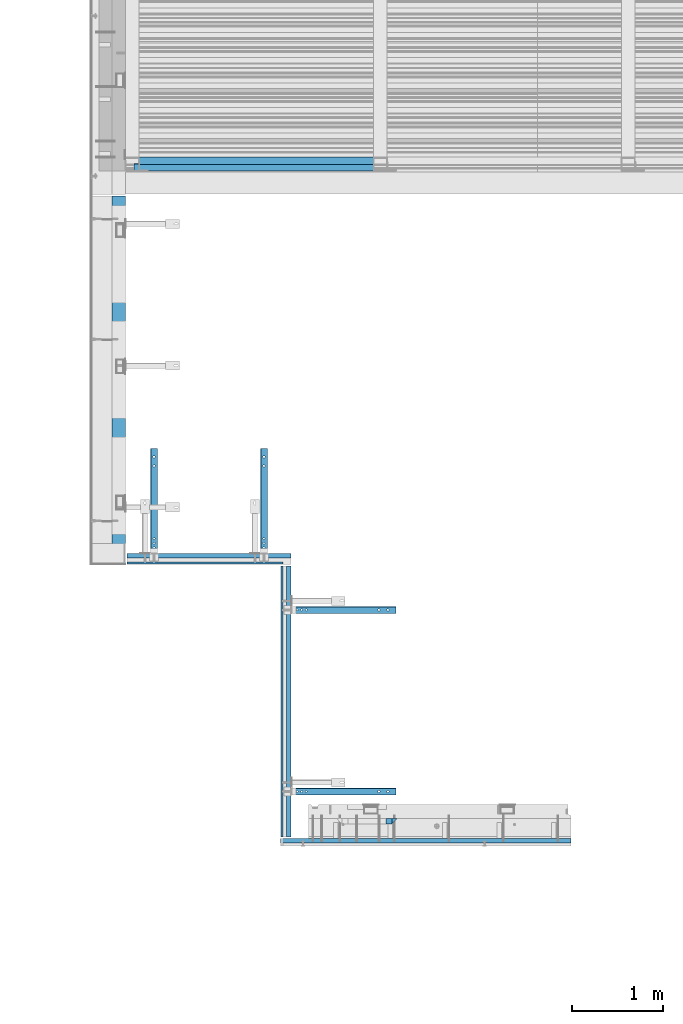
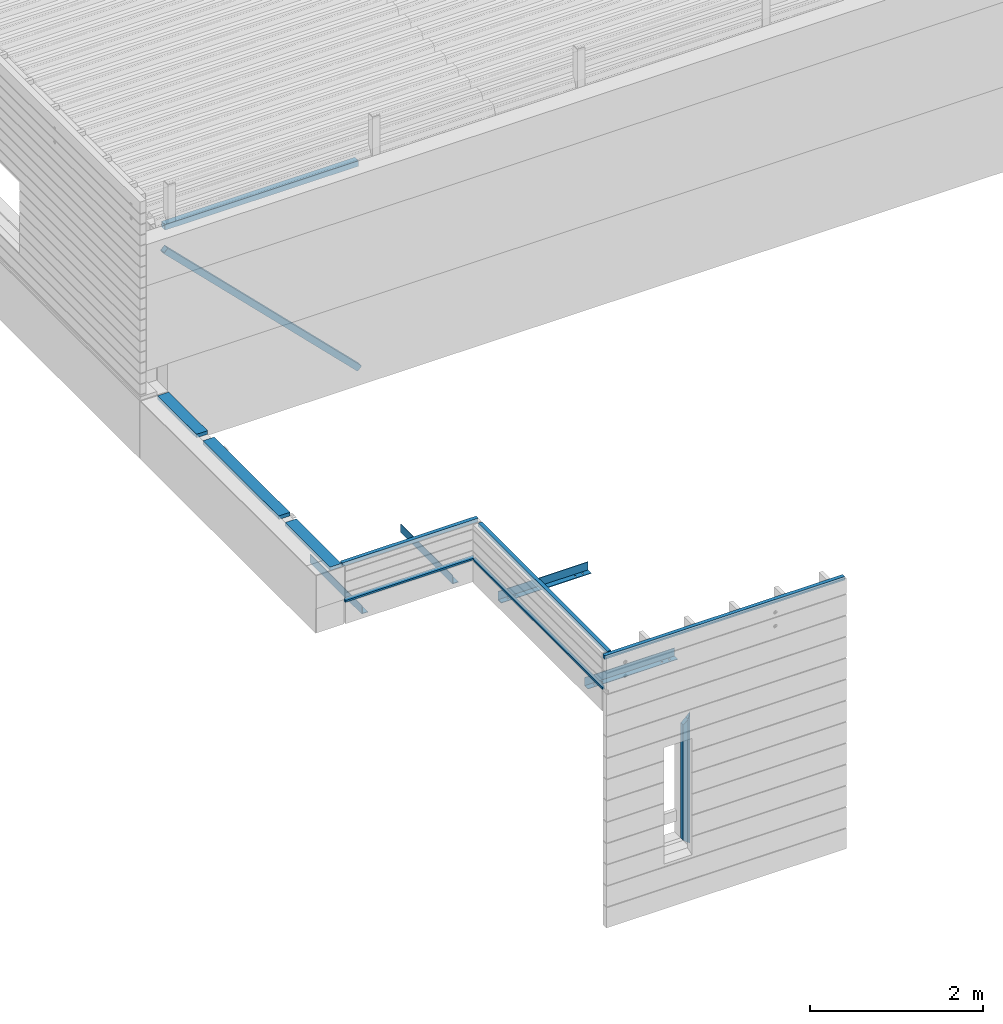
# One storey, part 17 of 153: 13 beams, 1 member, 10 elements without a shape of their own.
"""IFC2X3 building model written with IfcOpenShell, lengths in millimetres."""

from ifc_helpers import new_model, si_unit, frame, origin_with_axes, place, context, subcontext, project, spatial, faceted_brep, material, type_object, element, aggregate, save


model = new_model("IFC2X3")

# Units and contexts
model_context = context("Model", 3, precision=1e-05, world=origin_with_axes())
body_context = subcontext(model_context, "Body", "Model", "MODEL_VIEW")
ifc_project = project(units=[si_unit("LENGTHUNIT", "METRE", prefix="MILLI"), si_unit("AREAUNIT", "SQUARE_METRE"), si_unit("VOLUMEUNIT", "CUBIC_METRE"), si_unit("MASSUNIT", "GRAM", prefix="KILO"), si_unit("TIMEUNIT", "SECOND"), si_unit("PLANEANGLEUNIT", "RADIAN"), si_unit("SOLIDANGLEUNIT", "STERADIAN"), si_unit("THERMODYNAMICTEMPERATUREUNIT", "DEGREE_CELSIUS"), si_unit("LUMINOUSINTENSITYUNIT", "LUMEN")], contexts=[model_context])

# Site, building, storey
site_placement = place(None, origin_with_axes())
site = spatial("IfcSite", under=ifc_project, at=site_placement, CompositionType="ELEMENT")
building_placement = place(site_placement, origin_with_axes())
building = spatial("IfcBuilding", under=site, at=building_placement, CompositionType="ELEMENT")
storey_placement = place(building_placement, origin_with_axes())
storey = spatial("IfcBuildingStorey", under=building, at=storey_placement, Name="8", CompositionType="ELEMENT", Elevation=0.0)

# Assembly, beam
assembly_1_placement = place(storey_placement, origin_with_axes())
assembly_1 = element("IfcElementAssembly", 1, at=assembly_1_placement, inside=storey, Name="Steel Assembly", AssemblyPlace="NOTDEFINED", PredefinedType="RIGID_FRAME")
ifc_material_1 = material(Name="STEEL/S355J2")
beam_type_1 = type_object("IfcBeamType", Name="80X80X4", PredefinedType="NOTDEFINED")
beam_1_placement = place(assembly_1_placement, frame((8150.0, 15090.0, 105625.0), z_axis=(0.0, 0.0, 1.0), x_axis=(1.0, 0.0, 0.0)))
beam_1 = element("IfcBeam", 2, at=beam_1_placement, type_object=beam_type_1, material=ifc_material_1, ObjectType="80X80X4", context=body_context, shape_type="Brep", body=[
    faceted_brep([(0.0, 36.0, -36.0), (0.0, -36.0, -36.0), (2580.0, -36.0, -36.0), (2580.0, 36.0, -36.0), (0.0, -36.0, 36.0), (2580.0, -36.0, 36.0), (0.0, 36.0, 36.0), (2580.0, 36.0, 36.0), (0.0, 40.0, -40.0), (0.0, 40.0, 40.0), (2580.0, 40.0, 40.0), (2580.0, 40.0, -40.0), (0.0, -40.0, 40.0), (2580.0, -40.0, 40.0), (0.0, -40.0, -40.0), (2580.0, -40.0, -40.0)], [[[0, 1, 2, 3]], [[1, 4, 5, 2]], [[4, 6, 7, 5]], [[6, 0, 3, 7]], [[8, 9, 10, 11]], [[9, 12, 13, 10]], [[12, 14, 15, 13]], [[14, 8, 11, 15]], [[13, 15, 11, 10], [5, 7, 3, 2]], [[14, 12, 9, 8], [6, 4, 1, 0]]]),
])
aggregate(assembly_1, [beam_1])

# Assembly, member
assembly_2_placement = place(storey_placement, origin_with_axes())
assembly_2 = element("IfcElementAssembly", 3, at=assembly_2_placement, inside=storey, Name="Steel Assembly", AssemblyPlace="NOTDEFINED", PredefinedType="RIGID_FRAME")
member_type = type_object("IfcMemberType", Name="80X80X4", PredefinedType="NOTDEFINED")
member_placement = place(assembly_2_placement, frame((8121.8311532132, 15020.0, 105345.630773414), z_axis=(0.704221169665493, 0.0, 0.709980664662753), x_axis=(0.709980664662755, 0.0, -0.704221169665491)))
member = element("IfcMember", 4, at=member_placement, type_object=member_type, material=ifc_material_1, ObjectType="80X80X4", context=body_context, shape_type="Brep", body=[
    faceted_brep([(0.0, 36.0, -36.0), (0.0, -36.0, -36.0), (3640.94422381049, -36.0, -36.0), (3640.94422381049, 36.0, -36.0), (0.0, -36.0, 36.0), (3640.94422381048, -36.0, 36.0), (0.0, 36.0, 36.0), (3640.94422381048, 36.0, 36.0), (0.0, 40.0, -40.0), (0.0, 40.0, 40.0), (3640.94422381048, 40.0, 40.0), (3640.94422381048, 40.0, -40.0), (0.0, -40.0, 40.0), (3640.94422381048, -40.0, 40.0), (0.0, -40.0, -40.0), (3640.94422381048, -40.0, -40.0)], [[[0, 1, 2, 3]], [[1, 4, 5, 2]], [[4, 6, 7, 5]], [[6, 0, 3, 7]], [[8, 9, 10, 11]], [[9, 12, 13, 10]], [[12, 14, 15, 13]], [[14, 8, 11, 15]], [[13, 15, 11, 10], [5, 7, 3, 2]], [[14, 12, 9, 8], [6, 4, 1, 0]]]),
])
aggregate(assembly_2, [member])

# Assembly, beam
assembly_3_placement = place(storey_placement, origin_with_axes())
assembly_3 = element("IfcElementAssembly", 5, at=assembly_3_placement, inside=storey, AssemblyPlace="NOTDEFINED", PredefinedType="REINFORCEMENT_UNIT")
ifc_material_2 = material(Name="TIMBER")
beam_type_2 = type_object("IfcBeamType", PredefinedType="NOTDEFINED")
beam_2_placement = place(assembly_3_placement, frame((7924.99993196862, 10714.9999787075, 103545.0), z_axis=(0.0, 0.0, 1.0), x_axis=(0.0, 1.0, 0.0)))
beam_2 = element("IfcBeam", 6, at=beam_2_placement, type_object=beam_type_2, material=ifc_material_2, context=body_context, shape_type="Brep", body=[
    faceted_brep([(0.0, -75.0, -25.0), (1.81898940354586e-12, -75.0000000000009, 25.0), (1.81898940354586e-12, 75.0, 25.0), (0.0, 75.0, -25.0), (1037.99987665833, 75.0, -25.0), (1037.99987848675, -75.0000000000009, -25.0), (1037.99987848675, -75.000039166418, 25.0), (1037.99987665833, 75.0, 25.0), (3087.99987848667, -75.000585816445, 25.0), (3087.99988553667, 75.0, 25.0), (3087.99988553667, 75.0, -25.0), (3087.99987848667, -75.0000000000018, -25.0), (3987.0019971991, -75.0000000000009, 25.0), (3987.0019971991, -75.0000000000009, -25.0), (3987.0019971991, 75.0, -25.0), (3987.0019971991, 75.0, 25.0), (2937.99987848667, -75.0005787664186, 25.0), (2937.99987848667, -75.0000000000018, -25.0), (2937.99987665825, 75.0, -25.0), (2937.99987665825, 75.0, 25.0), (1187.99987848675, -75.0000462164453, 25.0), (1187.99988553675, 75.0, 25.0), (1187.99988553675, 75.0, -25.0), (1187.99987848675, -75.0000000000018, -25.0)], [[[0, 1, 2, 3]], [[0, 3, 4, 5]], [[1, 0, 5, 6]], [[2, 1, 6, 7]], [[3, 2, 7, 4]], [[6, 5, 4, 7]], [[8, 9, 10, 11]], [[12, 13, 14, 15]], [[13, 12, 8, 11]], [[14, 13, 11, 10]], [[15, 14, 10, 9]], [[12, 15, 9, 8]], [[16, 17, 18, 19]], [[20, 21, 22, 23]], [[21, 20, 16, 19]], [[22, 21, 19, 18]], [[23, 22, 18, 17]], [[20, 23, 17, 16]]]),
])
aggregate(assembly_3, [beam_2])

assembly_4_placement = place(storey_placement, origin_with_axes())
assembly_4 = element("IfcElementAssembly", 7, at=assembly_4_placement, inside=storey, AssemblyPlace="NOTDEFINED", PredefinedType="REINFORCEMENT_UNIT")
ifc_material_3 = material(Name="TIMBER/T24")
beam_type_3 = type_object("IfcBeamType", PredefinedType="NOTDEFINED")
beam_3_placement = place(assembly_4_placement, frame((9735.00005960496, 10662.5, 103080.0), z_axis=(0.0, -1.0, 0.0), x_axis=(-1.0, 3.00000001838171e-08, 0.0)))
beam_3 = element("IfcBeam", 8, at=beam_3_placement, type_object=beam_type_3, material=ifc_material_3, context=body_context, shape_type="Brep", body=[
    faceted_brep([(0.0, -25.0, -12.5), (1720.00000000001, -25.0, -12.5), (1720.00000000001, -1.16415321826935e-10, 12.5), (1.45519152283669e-11, -3.63797880709171e-12, 12.4999999999964), (0.0, 25.0, -12.5), (0.0, 25.0, 12.5), (1720.00000000001, 25.0, 12.5), (1720.00000000001, 25.0, -12.5)], [[[0, 1, 2, 3]], [[4, 5, 6, 7]], [[5, 4, 0, 3]], [[6, 5, 3, 2]], [[7, 6, 2, 1]], [[4, 7, 1, 0]]]),
])

assembly_5_placement = place(storey_placement, origin_with_axes())
assembly_5 = element("IfcElementAssembly", 9, at=assembly_5_placement, inside=storey, AssemblyPlace="NOTDEFINED", PredefinedType="REINFORCEMENT_UNIT")
beam_4_placement = place(assembly_5_placement, frame((9722.5, 7645.0, 103080.0), z_axis=(-1.0, 3.00000001838171e-08, 0.0), x_axis=(0.0, 1.0, 0.0)))
beam_4 = element("IfcBeam", 10, at=beam_4_placement, type_object=beam_type_3, material=ifc_material_3, context=body_context, shape_type="Brep", body=[
    faceted_brep([(2985.0, -25.0000000000291, -12.5000000000036), (2985.0, -2.91038304567337e-11, 12.5), (1.45519152283669e-11, -3.63797880709171e-12, 12.4999999999964), (0.0, -25.0, -12.5), (0.0, 25.0, -12.5), (0.0, 25.0, 12.5), (2985.0, 25.0, 12.5), (2985.0, 25.0, -12.5)], [[[0, 1, 2, 3]], [[4, 5, 6, 7]], [[4, 7, 0, 3]], [[5, 4, 3, 2]], [[6, 5, 2, 1]], [[7, 6, 1, 0]]]),
])

assembly_6_placement = place(storey_placement, origin_with_axes())
assembly_6 = element("IfcElementAssembly", 11, at=assembly_6_placement, inside=storey, Name="Steel Assembly", AssemblyPlace="NOTDEFINED", PredefinedType="RIGID_FRAME")
ifc_material_4 = material(Name="STEEL/S235J2")
beam_type_4 = type_object("IfcBeamType", PredefinedType="NOTDEFINED")
beam_5_placement = place(assembly_6_placement, frame((8315.00005960493, 10720.0, 102815.0), z_axis=(0.0, 0.0, 1.0), x_axis=(0.0, 1.0, 0.0)))
beam_5 = element("IfcBeam", 12, at=beam_5_placement, type_object=beam_type_4, material=ifc_material_4, context=body_context, shape_type="Brep", body=[
    faceted_brep([(152.928932188135, -7.07106781186485, -52.0), (152.928932188135, -7.07106781186485, -60.0), (150.0, 0.0, -60.0), (150.0, 0.0, -52.0), (152.928932188135, 7.07106781186485, -60.0), (152.928932188135, 7.07106781186485, -52.0), (160.0, 10.0, -60.0), (160.0, 10.0, -52.0), (167.071067811865, 7.07106781186485, -60.0), (167.071067811865, 7.07106781186485, -52.0), (170.0, 0.0, -60.0), (170.0, 0.0, -52.0), (167.071067811865, -7.07106781186485, -60.0), (167.071067811865, -7.07106781186485, -52.0), (160.0, -10.0, -60.0), (160.0, -10.0, -52.0), (0.0, -40.0, -52.0), (0.0, -40.0, -60.0), (1200.0, -40.0, -60.0), (1200.0, -40.0, -52.0), (0.0, 32.0, -52.0), (0.0, 32.0, 60.0), (0.0, 40.0, 60.0), (0.0, 40.0, -60.0), (1200.0, 32.0, -52.0), (1200.0, 32.0, 60.0), (1200.0, 40.0, 60.0), (1200.0, 40.0, -60.0), (1115.75, -9.95929214352145, -52.0), (1115.75, -9.95929214352145, -60.0), (1110.0, -11.5, -60.0), (1110.0, -11.5, -52.0), (1119.95929214352, -5.75, -52.0), (1119.95929214352, -5.75, -60.0), (1121.5, 0.0, -52.0), (1121.5, 0.0, -60.0), (1119.95929214352, 5.75, -52.0), (1119.95929214352, 5.75, -60.0), (1115.75, 9.95929214352145, -52.0), (1115.75, 9.95929214352145, -60.0), (1110.0, 11.5, -52.0), (1110.0, 11.5, -60.0), (1104.25, 9.95929214352145, -52.0), (1104.25, 9.95929214352145, -60.0), (1100.04070785648, 5.75, -52.0), (1100.04070785648, 5.75, -60.0), (1098.5, 0.0, -52.0), (1098.5, 0.0, -60.0), (1100.04070785648, -5.75, -52.0), (1100.04070785648, -5.75, -60.0), (1104.25, -9.95929214352145, -52.0), (1104.25, -9.95929214352145, -60.0), (1015.75, -9.95929214352145, -52.0), (1015.75, -9.95929214352145, -60.0), (1010.0, -11.5, -60.0), (1010.0, -11.5, -52.0), (1019.95929214352, -5.75, -52.0), (1019.95929214352, -5.75, -60.0), (1021.5, 0.0, -52.0), (1021.5, 0.0, -60.0), (1019.95929214352, 5.75, -52.0), (1019.95929214352, 5.75, -60.0), (1015.75, 9.95929214352145, -52.0), (1015.75, 9.95929214352145, -60.0), (1010.0, 11.5, -52.0), (1010.0, 11.5, -60.0), (1004.25, 9.95929214352145, -52.0), (1004.25, 9.95929214352145, -60.0), (1000.04070785648, 5.75, -52.0), (1000.04070785648, 5.75, -60.0), (998.5, 0.0, -52.0), (998.5, 0.0, -60.0), (1000.04070785648, -5.75, -52.0), (1000.04070785648, -5.75, -60.0), (1004.25, -9.95929214352145, -52.0), (1004.25, -9.95929214352145, -60.0), (117.071067811865, -7.07106781186485, -52.0), (117.071067811865, -7.07106781186485, -60.0), (110.0, -10.0, -60.0), (110.0, -10.0, -52.0), (120.0, 0.0, -52.0), (120.0, 0.0, -60.0), (117.071067811865, 7.07106781186485, -52.0), (117.071067811865, 7.07106781186485, -60.0), (110.0, 10.0, -52.0), (110.0, 10.0, -60.0), (102.928932188135, 7.07106781186485, -52.0), (102.928932188135, 7.07106781186485, -60.0), (100.0, 0.0, -52.0), (100.0, 0.0, -60.0), (102.928932188135, -7.07106781186485, -52.0), (102.928932188135, -7.07106781186485, -60.0), (200.0, 0.0, -52.0), (202.928932188135, 7.07106781186485, -52.0), (210.0, 10.0, -52.0), (217.071067811865, 7.07106781186485, -52.0), (220.0, 0.0, -52.0), (217.071067811865, -7.07106781186485, -52.0), (210.0, -10.0, -52.0), (202.928932188135, -7.07106781186485, -52.0), (220.0, 0.0, -60.0), (217.071067811865, -7.07106781186485, -60.0), (217.071067811865, 7.07106781186485, -60.0), (210.0, 10.0, -60.0), (202.928932188135, 7.07106781186485, -60.0), (200.0, 0.0, -60.0), (202.928932188135, -7.07106781186485, -60.0), (210.0, -10.0, -60.0)], [[[0, 1, 2, 3]], [[3, 2, 4, 5]], [[5, 4, 6, 7]], [[7, 6, 8, 9]], [[9, 8, 10, 11]], [[11, 10, 12, 13]], [[13, 12, 14, 15]], [[15, 14, 1, 0]], [[16, 17, 18, 19]], [[17, 16, 20, 21, 22, 23]], [[21, 20, 24, 25]], [[22, 21, 25, 26]], [[23, 22, 26, 27]], [[25, 24, 19, 18, 27, 26]], [[28, 29, 30, 31]], [[32, 33, 29, 28]], [[34, 35, 33, 32]], [[36, 37, 35, 34]], [[38, 39, 37, 36]], [[40, 41, 39, 38]], [[42, 43, 41, 40]], [[44, 45, 43, 42]], [[46, 47, 45, 44]], [[48, 49, 47, 46]], [[50, 51, 49, 48]], [[31, 30, 51, 50]], [[52, 53, 54, 55]], [[56, 57, 53, 52]], [[58, 59, 57, 56]], [[60, 61, 59, 58]], [[62, 63, 61, 60]], [[64, 65, 63, 62]], [[66, 67, 65, 64]], [[68, 69, 67, 66]], [[70, 71, 69, 68]], [[72, 73, 71, 70]], [[74, 75, 73, 72]], [[55, 54, 75, 74]], [[76, 77, 78, 79]], [[80, 81, 77, 76]], [[82, 83, 81, 80]], [[84, 85, 83, 82]], [[86, 87, 85, 84]], [[88, 89, 87, 86]], [[90, 91, 89, 88]], [[79, 78, 91, 90]], [[20, 16, 19, 24], [3, 5, 7, 9, 11, 13, 15, 0], [92, 93, 94, 95, 96, 97, 98, 99], [88, 86, 84, 82, 80, 76, 79, 90], [72, 70, 68, 66, 64, 62, 60, 58, 56, 52, 55, 74], [48, 46, 44, 42, 40, 38, 36, 34, 32, 28, 31, 50]], [[96, 100, 101, 97]], [[95, 102, 100, 96]], [[94, 103, 102, 95]], [[93, 104, 103, 94]], [[92, 105, 104, 93]], [[99, 106, 105, 92]], [[98, 107, 106, 99]], [[97, 101, 107, 98]], [[17, 23, 27, 18], [10, 8, 6, 4, 2, 1, 14, 12], [100, 102, 103, 104, 105, 106, 107, 101], [81, 83, 85, 87, 89, 91, 78, 77], [57, 59, 61, 63, 65, 67, 69, 71, 73, 75, 54, 53], [33, 35, 37, 39, 41, 43, 45, 47, 49, 51, 30, 29]]]),
])
aggregate(assembly_6, [beam_5])

assembly_7_placement = place(storey_placement, origin_with_axes())
assembly_7 = element("IfcElementAssembly", 13, at=assembly_7_placement, inside=storey, Name="Steel Assembly", AssemblyPlace="NOTDEFINED", PredefinedType="RIGID_FRAME")
beam_6_placement = place(assembly_7_placement, frame((9779.99999999999, 10145.0, 102815.0), z_axis=(0.0, 0.0, 1.0), x_axis=(1.0, 0.0, 0.0)))
beam_6 = element("IfcBeam", 14, at=beam_6_placement, type_object=beam_type_4, material=ifc_material_4, context=body_context, shape_type="Brep", body=[
    faceted_brep([(167.071067811865, -7.07106781186485, -52.0), (167.071067811865, -7.07106781186485, -60.0), (160.0, -10.0, -60.0), (160.0, -10.0, -52.0), (152.928932188135, -7.07106781186485, -60.0), (152.928932188135, -7.07106781186485, -52.0), (150.0, 0.0, -60.0), (150.0, 0.0, -52.0), (152.928932188135, 7.07106781186485, -60.0), (152.928932188135, 7.07106781186485, -52.0), (160.0, 10.0, -60.0), (160.0, 10.0, -52.0), (167.071067811865, 7.07106781186485, -60.0), (167.071067811865, 7.07106781186485, -52.0), (170.0, 0.0, -60.0), (170.0, 0.0, -52.0), (0.0, -40.0, -52.0), (0.0, -40.0, -60.0), (1200.0, -40.0, -60.0), (1200.0, -40.0, -52.0), (0.0, 32.0, -52.0), (0.0, 32.0, 60.0), (0.0, 40.0, 60.0), (0.0, 40.0, -60.0), (1200.0, 32.0, -52.0), (1200.0, 32.0, 60.0), (1200.0, 40.0, 60.0), (1200.0, 40.0, -60.0), (1119.95929214352, 5.75, -52.0), (1119.95929214352, 5.75, -60.0), (1121.5, 0.0, -60.0), (1121.5, 0.0, -52.0), (1115.75, 9.95929214352145, -52.0), (1115.75, 9.95929214352145, -60.0), (1110.0, 11.5, -52.0), (1110.0, 11.5, -60.0), (1104.25, 9.95929214352145, -52.0), (1104.25, 9.95929214352145, -60.0), (1100.04070785648, 5.75, -52.0), (1100.04070785648, 5.75, -60.0), (1098.5, 0.0, -52.0), (1098.5, 0.0, -60.0), (1100.04070785648, -5.75, -52.0), (1100.04070785648, -5.75, -60.0), (1104.25, -9.95929214352145, -52.0), (1104.25, -9.95929214352145, -60.0), (1110.0, -11.5, -52.0), (1110.0, -11.5, -60.0), (1115.75, -9.95929214352145, -52.0), (1115.75, -9.95929214352145, -60.0), (1119.95929214352, -5.75, -52.0), (1119.95929214352, -5.75, -60.0), (1019.95929214352, 5.75, -52.0), (1019.95929214352, 5.75, -60.0), (1021.5, 0.0, -60.0), (1021.5, 0.0, -52.0), (1015.75, 9.95929214352145, -52.0), (1015.75, 9.95929214352145, -60.0), (1010.0, 11.5, -52.0), (1010.0, 11.5, -60.0), (1004.25, 9.95929214352145, -52.0), (1004.25, 9.95929214352145, -60.0), (1000.04070785648, 5.75, -52.0), (1000.04070785648, 5.75, -60.0), (998.5, 0.0, -52.0), (998.5, 0.0, -60.0), (1000.04070785648, -5.75, -52.0), (1000.04070785648, -5.75, -60.0), (1004.25, -9.95929214352145, -52.0), (1004.25, -9.95929214352145, -60.0), (1010.0, -11.5, -52.0), (1010.0, -11.5, -60.0), (1015.75, -9.95929214352145, -52.0), (1015.75, -9.95929214352145, -60.0), (1019.95929214352, -5.75, -52.0), (1019.95929214352, -5.75, -60.0), (117.071067811865, 7.07106781186485, -52.0), (117.071067811865, 7.07106781186485, -60.0), (120.0, 0.0, -60.0), (120.0, 0.0, -52.0), (110.0, 10.0, -52.0), (110.0, 10.0, -60.0), (102.928932188135, 7.07106781186485, -52.0), (102.928932188135, 7.07106781186485, -60.0), (100.0, 0.0, -52.0), (100.0, 0.0, -60.0), (102.928932188135, -7.07106781186485, -52.0), (102.928932188135, -7.07106781186485, -60.0), (110.0, -10.0, -52.0), (110.0, -10.0, -60.0), (117.071067811865, -7.07106781186485, -52.0), (117.071067811865, -7.07106781186485, -60.0), (200.0, 0.0, -52.0), (202.928932188135, 7.07106781186485, -52.0), (210.0, 10.0, -52.0), (217.071067811865, 7.07106781186485, -52.0), (220.0, 0.0, -52.0), (217.071067811865, -7.07106781186485, -52.0), (210.0, -10.0, -52.0), (202.928932188135, -7.07106781186485, -52.0), (210.0, 10.0, -60.0), (217.071067811865, 7.07106781186485, -60.0), (202.928932188135, 7.07106781186485, -60.0), (200.0, 0.0, -60.0), (202.928932188135, -7.07106781186485, -60.0), (210.0, -10.0, -60.0), (217.071067811865, -7.07106781186485, -60.0), (220.0, 0.0, -60.0)], [[[0, 1, 2, 3]], [[3, 2, 4, 5]], [[5, 4, 6, 7]], [[7, 6, 8, 9]], [[9, 8, 10, 11]], [[11, 10, 12, 13]], [[13, 12, 14, 15]], [[15, 14, 1, 0]], [[16, 17, 18, 19]], [[17, 16, 20, 21, 22, 23]], [[21, 20, 24, 25]], [[22, 21, 25, 26]], [[23, 22, 26, 27]], [[25, 24, 19, 18, 27, 26]], [[28, 29, 30, 31]], [[32, 33, 29, 28]], [[34, 35, 33, 32]], [[36, 37, 35, 34]], [[38, 39, 37, 36]], [[40, 41, 39, 38]], [[42, 43, 41, 40]], [[44, 45, 43, 42]], [[46, 47, 45, 44]], [[48, 49, 47, 46]], [[50, 51, 49, 48]], [[31, 30, 51, 50]], [[52, 53, 54, 55]], [[56, 57, 53, 52]], [[58, 59, 57, 56]], [[60, 61, 59, 58]], [[62, 63, 61, 60]], [[64, 65, 63, 62]], [[66, 67, 65, 64]], [[68, 69, 67, 66]], [[70, 71, 69, 68]], [[72, 73, 71, 70]], [[74, 75, 73, 72]], [[55, 54, 75, 74]], [[76, 77, 78, 79]], [[80, 81, 77, 76]], [[82, 83, 81, 80]], [[84, 85, 83, 82]], [[86, 87, 85, 84]], [[88, 89, 87, 86]], [[90, 91, 89, 88]], [[79, 78, 91, 90]], [[20, 16, 19, 24], [7, 9, 11, 13, 15, 0, 3, 5], [92, 93, 94, 95, 96, 97, 98, 99], [84, 82, 80, 76, 79, 90, 88, 86], [66, 64, 62, 60, 58, 56, 52, 55, 74, 72, 70, 68], [42, 40, 38, 36, 34, 32, 28, 31, 50, 48, 46, 44]], [[94, 100, 101, 95]], [[93, 102, 100, 94]], [[92, 103, 102, 93]], [[99, 104, 103, 92]], [[98, 105, 104, 99]], [[97, 106, 105, 98]], [[96, 107, 106, 97]], [[95, 101, 107, 96]], [[17, 23, 27, 18], [14, 12, 10, 8, 6, 4, 2, 1], [107, 101, 100, 102, 103, 104, 105, 106], [78, 77, 81, 83, 85, 87, 89, 91], [75, 54, 53, 57, 59, 61, 63, 65, 67, 69, 71, 73], [51, 30, 29, 33, 35, 37, 39, 41, 43, 45, 47, 49]]]),
])
aggregate(assembly_7, [beam_6])

assembly_8_placement = place(storey_placement, origin_with_axes())
assembly_8 = element("IfcElementAssembly", 15, at=assembly_8_placement, inside=storey, Name="Steel Assembly", AssemblyPlace="NOTDEFINED", PredefinedType="RIGID_FRAME")
beam_7_placement = place(assembly_8_placement, frame((9525.0, 10720.0, 102815.0), z_axis=(0.0, 0.0, 1.0), x_axis=(0.0, 1.0, 0.0)))
beam_7 = element("IfcBeam", 16, at=beam_7_placement, type_object=beam_type_4, material=ifc_material_4, context=body_context, shape_type="Brep", body=[
    faceted_brep([(152.928932188135, -7.07106781186485, -52.0), (152.928932188135, -7.07106781186485, -60.0), (150.0, 0.0, -60.0), (150.0, 0.0, -52.0), (152.928932188135, 7.07106781186485, -60.0), (152.928932188135, 7.07106781186485, -52.0), (160.0, 10.0, -60.0), (160.0, 10.0, -52.0), (167.071067811865, 7.07106781186485, -60.0), (167.071067811865, 7.07106781186485, -52.0), (170.0, 0.0, -60.0), (170.0, 0.0, -52.0), (167.071067811865, -7.07106781186485, -60.0), (167.071067811865, -7.07106781186485, -52.0), (160.0, -10.0, -60.0), (160.0, -10.0, -52.0), (0.0, -40.0, -52.0), (0.0, -40.0, -60.0), (1200.0, -40.0, -60.0), (1200.0, -40.0, -52.0), (0.0, 32.0, -52.0), (0.0, 32.0, 60.0), (0.0, 40.0, 60.0), (0.0, 40.0, -60.0), (1200.0, 32.0, -52.0), (1200.0, 32.0, 60.0), (1200.0, 40.0, 60.0), (1200.0, 40.0, -60.0), (1115.75, -9.95929214352145, -52.0), (1115.75, -9.95929214352145, -60.0), (1110.0, -11.5, -60.0), (1110.0, -11.5, -52.0), (1119.95929214352, -5.75, -52.0), (1119.95929214352, -5.75, -60.0), (1121.5, 0.0, -52.0), (1121.5, 0.0, -60.0), (1119.95929214352, 5.75, -52.0), (1119.95929214352, 5.75, -60.0), (1115.75, 9.95929214352145, -52.0), (1115.75, 9.95929214352145, -60.0), (1110.0, 11.5, -52.0), (1110.0, 11.5, -60.0), (1104.25, 9.95929214352145, -52.0), (1104.25, 9.95929214352145, -60.0), (1100.04070785648, 5.75, -52.0), (1100.04070785648, 5.75, -60.0), (1098.5, 0.0, -52.0), (1098.5, 0.0, -60.0), (1100.04070785648, -5.75, -52.0), (1100.04070785648, -5.75, -60.0), (1104.25, -9.95929214352145, -52.0), (1104.25, -9.95929214352145, -60.0), (1015.75, -9.95929214352145, -52.0), (1015.75, -9.95929214352145, -60.0), (1010.0, -11.5, -60.0), (1010.0, -11.5, -52.0), (1019.95929214352, -5.75, -52.0), (1019.95929214352, -5.75, -60.0), (1021.5, 0.0, -52.0), (1021.5, 0.0, -60.0), (1019.95929214352, 5.75, -52.0), (1019.95929214352, 5.75, -60.0), (1015.75, 9.95929214352145, -52.0), (1015.75, 9.95929214352145, -60.0), (1010.0, 11.5, -52.0), (1010.0, 11.5, -60.0), (1004.25, 9.95929214352145, -52.0), (1004.25, 9.95929214352145, -60.0), (1000.04070785648, 5.75, -52.0), (1000.04070785648, 5.75, -60.0), (998.5, 0.0, -52.0), (998.5, 0.0, -60.0), (1000.04070785648, -5.75, -52.0), (1000.04070785648, -5.75, -60.0), (1004.25, -9.95929214352145, -52.0), (1004.25, -9.95929214352145, -60.0), (117.071067811865, -7.07106781186485, -52.0), (117.071067811865, -7.07106781186485, -60.0), (110.0, -10.0, -60.0), (110.0, -10.0, -52.0), (120.0, 0.0, -52.0), (120.0, 0.0, -60.0), (117.071067811865, 7.07106781186485, -52.0), (117.071067811865, 7.07106781186485, -60.0), (110.0, 10.0, -52.0), (110.0, 10.0, -60.0), (102.928932188135, 7.07106781186485, -52.0), (102.928932188135, 7.07106781186485, -60.0), (100.0, 0.0, -52.0), (100.0, 0.0, -60.0), (102.928932188135, -7.07106781186485, -52.0), (102.928932188135, -7.07106781186485, -60.0), (200.0, 0.0, -52.0), (202.928932188135, 7.07106781186485, -52.0), (210.0, 10.0, -52.0), (217.071067811865, 7.07106781186485, -52.0), (220.0, 0.0, -52.0), (217.071067811865, -7.07106781186485, -52.0), (210.0, -10.0, -52.0), (202.928932188135, -7.07106781186485, -52.0), (220.0, 0.0, -60.0), (217.071067811865, -7.07106781186485, -60.0), (217.071067811865, 7.07106781186485, -60.0), (210.0, 10.0, -60.0), (202.928932188135, 7.07106781186485, -60.0), (200.0, 0.0, -60.0), (202.928932188135, -7.07106781186485, -60.0), (210.0, -10.0, -60.0)], [[[0, 1, 2, 3]], [[3, 2, 4, 5]], [[5, 4, 6, 7]], [[7, 6, 8, 9]], [[9, 8, 10, 11]], [[11, 10, 12, 13]], [[13, 12, 14, 15]], [[15, 14, 1, 0]], [[16, 17, 18, 19]], [[17, 16, 20, 21, 22, 23]], [[21, 20, 24, 25]], [[22, 21, 25, 26]], [[23, 22, 26, 27]], [[25, 24, 19, 18, 27, 26]], [[28, 29, 30, 31]], [[32, 33, 29, 28]], [[34, 35, 33, 32]], [[36, 37, 35, 34]], [[38, 39, 37, 36]], [[40, 41, 39, 38]], [[42, 43, 41, 40]], [[44, 45, 43, 42]], [[46, 47, 45, 44]], [[48, 49, 47, 46]], [[50, 51, 49, 48]], [[31, 30, 51, 50]], [[52, 53, 54, 55]], [[56, 57, 53, 52]], [[58, 59, 57, 56]], [[60, 61, 59, 58]], [[62, 63, 61, 60]], [[64, 65, 63, 62]], [[66, 67, 65, 64]], [[68, 69, 67, 66]], [[70, 71, 69, 68]], [[72, 73, 71, 70]], [[74, 75, 73, 72]], [[55, 54, 75, 74]], [[76, 77, 78, 79]], [[80, 81, 77, 76]], [[82, 83, 81, 80]], [[84, 85, 83, 82]], [[86, 87, 85, 84]], [[88, 89, 87, 86]], [[90, 91, 89, 88]], [[79, 78, 91, 90]], [[20, 16, 19, 24], [3, 5, 7, 9, 11, 13, 15, 0], [92, 93, 94, 95, 96, 97, 98, 99], [88, 86, 84, 82, 80, 76, 79, 90], [72, 70, 68, 66, 64, 62, 60, 58, 56, 52, 55, 74], [48, 46, 44, 42, 40, 38, 36, 34, 32, 28, 31, 50]], [[96, 100, 101, 97]], [[95, 102, 100, 96]], [[94, 103, 102, 95]], [[93, 104, 103, 94]], [[92, 105, 104, 93]], [[99, 106, 105, 92]], [[98, 107, 106, 99]], [[97, 101, 107, 98]], [[17, 23, 27, 18], [10, 8, 6, 4, 2, 1, 14, 12], [100, 102, 103, 104, 105, 106, 107, 101], [81, 83, 85, 87, 89, 91, 78, 77], [57, 59, 61, 63, 65, 67, 69, 71, 73, 75, 54, 53], [33, 35, 37, 39, 41, 43, 45, 47, 49, 51, 30, 29]]]),
])
aggregate(assembly_8, [beam_7])

assembly_9_placement = place(storey_placement, origin_with_axes())
assembly_9 = element("IfcElementAssembly", 17, at=assembly_9_placement, inside=storey, Name="Steel Assembly", AssemblyPlace="NOTDEFINED", PredefinedType="RIGID_FRAME")
beam_8_placement = place(assembly_9_placement, frame((9779.99999999999, 8145.0, 102815.0), z_axis=(0.0, 0.0, 1.0), x_axis=(1.0, 0.0, 0.0)))
beam_8 = element("IfcBeam", 18, at=beam_8_placement, type_object=beam_type_4, material=ifc_material_4, context=body_context, shape_type="Brep", body=[
    faceted_brep([(167.071067811865, -7.07106781186485, -52.0), (167.071067811865, -7.07106781186485, -60.0), (160.0, -10.0, -60.0), (160.0, -10.0, -52.0), (152.928932188135, -7.07106781186485, -60.0), (152.928932188135, -7.07106781186485, -52.0), (150.0, 0.0, -60.0), (150.0, 0.0, -52.0), (152.928932188135, 7.07106781186485, -60.0), (152.928932188135, 7.07106781186485, -52.0), (160.0, 10.0, -60.0), (160.0, 10.0, -52.0), (167.071067811865, 7.07106781186485, -60.0), (167.071067811865, 7.07106781186485, -52.0), (170.0, 0.0, -60.0), (170.0, 0.0, -52.0), (0.0, -40.0, -52.0), (0.0, -40.0, -60.0), (1200.0, -40.0, -60.0), (1200.0, -40.0, -52.0), (0.0, 32.0, -52.0), (0.0, 32.0, 60.0), (0.0, 40.0, 60.0), (0.0, 40.0, -60.0), (1200.0, 32.0, -52.0), (1200.0, 32.0, 60.0), (1200.0, 40.0, 60.0), (1200.0, 40.0, -60.0), (1119.95929214352, 5.75, -52.0), (1119.95929214352, 5.75, -60.0), (1121.5, 0.0, -60.0), (1121.5, 0.0, -52.0), (1115.75, 9.95929214352145, -52.0), (1115.75, 9.95929214352145, -60.0), (1110.0, 11.5, -52.0), (1110.0, 11.5, -60.0), (1104.25, 9.95929214352145, -52.0), (1104.25, 9.95929214352145, -60.0), (1100.04070785648, 5.75, -52.0), (1100.04070785648, 5.75, -60.0), (1098.5, 0.0, -52.0), (1098.5, 0.0, -60.0), (1100.04070785648, -5.75, -52.0), (1100.04070785648, -5.75, -60.0), (1104.25, -9.95929214352145, -52.0), (1104.25, -9.95929214352145, -60.0), (1110.0, -11.5, -52.0), (1110.0, -11.5, -60.0), (1115.75, -9.95929214352145, -52.0), (1115.75, -9.95929214352145, -60.0), (1119.95929214352, -5.75, -52.0), (1119.95929214352, -5.75, -60.0), (1019.95929214352, 5.75, -52.0), (1019.95929214352, 5.75, -60.0), (1021.5, 0.0, -60.0), (1021.5, 0.0, -52.0), (1015.75, 9.95929214352145, -52.0), (1015.75, 9.95929214352145, -60.0), (1010.0, 11.5, -52.0), (1010.0, 11.5, -60.0), (1004.25, 9.95929214352145, -52.0), (1004.25, 9.95929214352145, -60.0), (1000.04070785648, 5.75, -52.0), (1000.04070785648, 5.75, -60.0), (998.5, 0.0, -52.0), (998.5, 0.0, -60.0), (1000.04070785648, -5.75, -52.0), (1000.04070785648, -5.75, -60.0), (1004.25, -9.95929214352145, -52.0), (1004.25, -9.95929214352145, -60.0), (1010.0, -11.5, -52.0), (1010.0, -11.5, -60.0), (1015.75, -9.95929214352145, -52.0), (1015.75, -9.95929214352145, -60.0), (1019.95929214352, -5.75, -52.0), (1019.95929214352, -5.75, -60.0), (117.071067811865, 7.07106781186485, -52.0), (117.071067811865, 7.07106781186485, -60.0), (120.0, 0.0, -60.0), (120.0, 0.0, -52.0), (110.0, 10.0, -52.0), (110.0, 10.0, -60.0), (102.928932188135, 7.07106781186485, -52.0), (102.928932188135, 7.07106781186485, -60.0), (100.0, 0.0, -52.0), (100.0, 0.0, -60.0), (102.928932188135, -7.07106781186485, -52.0), (102.928932188135, -7.07106781186485, -60.0), (110.0, -10.0, -52.0), (110.0, -10.0, -60.0), (117.071067811865, -7.07106781186485, -52.0), (117.071067811865, -7.07106781186485, -60.0), (200.0, 0.0, -52.0), (202.928932188135, 7.07106781186485, -52.0), (210.0, 10.0, -52.0), (217.071067811865, 7.07106781186485, -52.0), (220.0, 0.0, -52.0), (217.071067811865, -7.07106781186485, -52.0), (210.0, -10.0, -52.0), (202.928932188135, -7.07106781186485, -52.0), (210.0, 10.0, -60.0), (217.071067811865, 7.07106781186485, -60.0), (202.928932188135, 7.07106781186485, -60.0), (200.0, 0.0, -60.0), (202.928932188135, -7.07106781186485, -60.0), (210.0, -10.0, -60.0), (217.071067811865, -7.07106781186485, -60.0), (220.0, 0.0, -60.0)], [[[0, 1, 2, 3]], [[3, 2, 4, 5]], [[5, 4, 6, 7]], [[7, 6, 8, 9]], [[9, 8, 10, 11]], [[11, 10, 12, 13]], [[13, 12, 14, 15]], [[15, 14, 1, 0]], [[16, 17, 18, 19]], [[17, 16, 20, 21, 22, 23]], [[21, 20, 24, 25]], [[22, 21, 25, 26]], [[23, 22, 26, 27]], [[25, 24, 19, 18, 27, 26]], [[28, 29, 30, 31]], [[32, 33, 29, 28]], [[34, 35, 33, 32]], [[36, 37, 35, 34]], [[38, 39, 37, 36]], [[40, 41, 39, 38]], [[42, 43, 41, 40]], [[44, 45, 43, 42]], [[46, 47, 45, 44]], [[48, 49, 47, 46]], [[50, 51, 49, 48]], [[31, 30, 51, 50]], [[52, 53, 54, 55]], [[56, 57, 53, 52]], [[58, 59, 57, 56]], [[60, 61, 59, 58]], [[62, 63, 61, 60]], [[64, 65, 63, 62]], [[66, 67, 65, 64]], [[68, 69, 67, 66]], [[70, 71, 69, 68]], [[72, 73, 71, 70]], [[74, 75, 73, 72]], [[55, 54, 75, 74]], [[76, 77, 78, 79]], [[80, 81, 77, 76]], [[82, 83, 81, 80]], [[84, 85, 83, 82]], [[86, 87, 85, 84]], [[88, 89, 87, 86]], [[90, 91, 89, 88]], [[79, 78, 91, 90]], [[20, 16, 19, 24], [7, 9, 11, 13, 15, 0, 3, 5], [92, 93, 94, 95, 96, 97, 98, 99], [84, 82, 80, 76, 79, 90, 88, 86], [66, 64, 62, 60, 58, 56, 52, 55, 74, 72, 70, 68], [42, 40, 38, 36, 34, 32, 28, 31, 50, 48, 46, 44]], [[94, 100, 101, 95]], [[93, 102, 100, 94]], [[92, 103, 102, 93]], [[99, 104, 103, 92]], [[98, 105, 104, 99]], [[97, 106, 105, 98]], [[96, 107, 106, 97]], [[95, 101, 107, 96]], [[17, 23, 27, 18], [14, 12, 10, 8, 6, 4, 2, 1], [107, 101, 100, 102, 103, 104, 105, 106], [78, 77, 81, 83, 85, 87, 89, 91], [75, 54, 53, 57, 59, 61, 63, 65, 67, 69, 71, 73], [51, 30, 29, 33, 35, 37, 39, 41, 43, 45, 47, 49]]]),
])
aggregate(assembly_9, [beam_8])

# Beam
beam_type_5 = type_object("IfcBeamType", Name="PK50X50", PredefinedType="NOTDEFINED")
beam_9_placement = place(assembly_4_placement, frame((8015.00005960493, 10740.0, 103545.0), z_axis=(0.0, 0.0, 1.0), x_axis=(1.0, 0.0, 0.0)))
beam_9 = element("IfcBeam", 19, at=beam_9_placement, type_object=beam_type_5, material=ifc_material_3, ObjectType="PK50X50", context=body_context, shape_type="Brep", body=[
    faceted_brep([(0.0, 25.0, 25.0), (0.0, -25.0, 25.0), (1809.99994039507, -25.0, 25.0), (1809.99994039507, 25.0, 25.0), (0.0, -25.0, -25.0), (1809.99994039507, -25.0, -25.0), (0.0, 25.0, -25.0), (1809.99994039507, 25.0, -25.0)], [[[0, 1, 2, 3]], [[1, 4, 5, 2]], [[4, 6, 7, 5]], [[6, 0, 3, 7]], [[5, 7, 3, 2]], [[4, 1, 0, 6]]]),
])

aggregate(assembly_4, [beam_3, beam_9])

beam_10_placement = place(assembly_5_placement, frame((9800.0, 10630.0, 103545.0), z_axis=(0.0, 0.0, 1.0), x_axis=(0.0, -1.0, 0.0)))
beam_10 = element("IfcBeam", 20, at=beam_10_placement, type_object=beam_type_5, material=ifc_material_3, ObjectType="PK50X50", context=body_context, shape_type="Brep", body=[
    faceted_brep([(0.0, 25.0, 25.0), (0.0, -25.0, 25.0), (2985.0, -25.0, 25.0), (2985.0, 25.0, 25.0), (0.0, -25.0, -25.0), (2985.0, -25.0, -25.0), (0.0, 25.0, -25.0), (2985.0, 25.0, -25.0)], [[[0, 1, 2, 3]], [[1, 4, 5, 2]], [[4, 6, 7, 5]], [[6, 0, 3, 7]], [[5, 7, 3, 2]], [[4, 1, 0, 6]]]),
])

aggregate(assembly_5, [beam_4, beam_10])

# Assembly, beams
assembly_10_placement = place(storey_placement, origin_with_axes())
assembly_10 = element("IfcElementAssembly", 21, at=assembly_10_placement, inside=storey, AssemblyPlace="NOTDEFINED", PredefinedType="REINFORCEMENT_UNIT")
beam_11_placement = place(assembly_10_placement, frame((12905.0, 7605.0, 103545.0), z_axis=(0.0, 0.0, 1.0), x_axis=(-1.0, 3.00000001838171e-08, 0.0)))
beam_11 = element("IfcBeam", 22, at=beam_11_placement, type_object=beam_type_5, material=ifc_material_3, ObjectType="PK50X50", context=body_context, shape_type="Brep", body=[
    faceted_brep([(0.0, 25.0, 25.0), (0.0, -25.0, 25.0), (3200.0, -25.0, 25.0), (3200.0, 25.0, 25.0), (0.0, -25.0, -25.0), (3200.0, -25.0, -25.0), (0.0, 25.0, -25.0), (3200.0, 25.0, -25.0)], [[[0, 1, 2, 3]], [[1, 4, 5, 2]], [[4, 6, 7, 5]], [[6, 0, 3, 7]], [[5, 7, 3, 2]], [[4, 1, 0, 6]]]),
])
ifc_material_5 = material(Name="CONCRETE/C25/30")
beam_type_6 = type_object("IfcBeamType", PredefinedType="NOTDEFINED")
beam_12_placement = place(assembly_10_placement, frame((10964.9994055559, 7820.0, 102175.0), z_axis=(-1.0, 3.00000001838171e-08, 0.0), x_axis=(0.0, 0.0, -1.0)))
beam_12 = element("IfcBeam", 23, at=beam_12_placement, type_object=beam_type_6, material=ifc_material_5, Name="SK", context=body_context, shape_type="Brep", body=[
    faceted_brep([(60.0000000000073, 30.0, 30.0), (0.0, -30.0, -30.0), (60.0000000000073, -30.0, 30.0), (1855.0, -30.0, -30.0), (1795.00000000001, -30.0, 30.0), (1795.00000000001, 30.0, 30.0)], [[[0, 1, 2]], [[3, 4, 2, 1]], [[4, 5, 0, 2]], [[5, 3, 1, 0]], [[4, 3, 5]]]),
])
beam_type_7 = type_object("IfcBeamType", PredefinedType="NOTDEFINED")
beam_13_placement = place(assembly_10_placement, frame((10899.9994055559, 7820.0, 102115.0), z_axis=(-1.0, 3.00000001838171e-08, 0.0), x_axis=(0.0, 0.0, -1.0)))
beam_13 = element("IfcBeam", 24, at=beam_13_placement, type_object=beam_type_7, material=ifc_material_5, Name="SK", context=body_context, shape_type="Brep", body=[
    faceted_brep([(0.0, -30.0, -35.0), (54.9034748914273, -30.0, 29.0540540540533), (56.2934362811066, 30.0, 30.6756756756768), (0.0, 30.0, -35.0), (1735.0, -30.0, -35.0), (1680.09652510857, -30.0, 29.0540540540533), (1678.70656371891, 30.0, 30.6756756756768), (1735.0, 30.0, -35.0)], [[[0, 1, 2, 3]], [[1, 0, 4, 5]], [[2, 1, 5, 6]], [[3, 2, 6, 7]], [[7, 4, 0, 3]], [[4, 7, 6, 5]]]),
])
aggregate(assembly_10, [beam_11, beam_12, beam_13])

save(model, "model.ifc")
